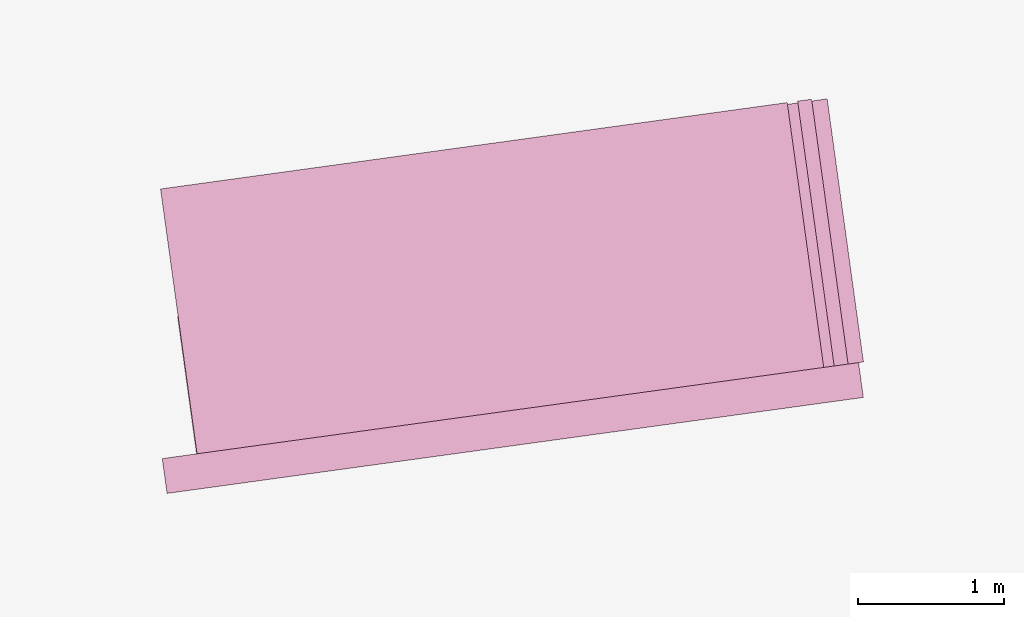
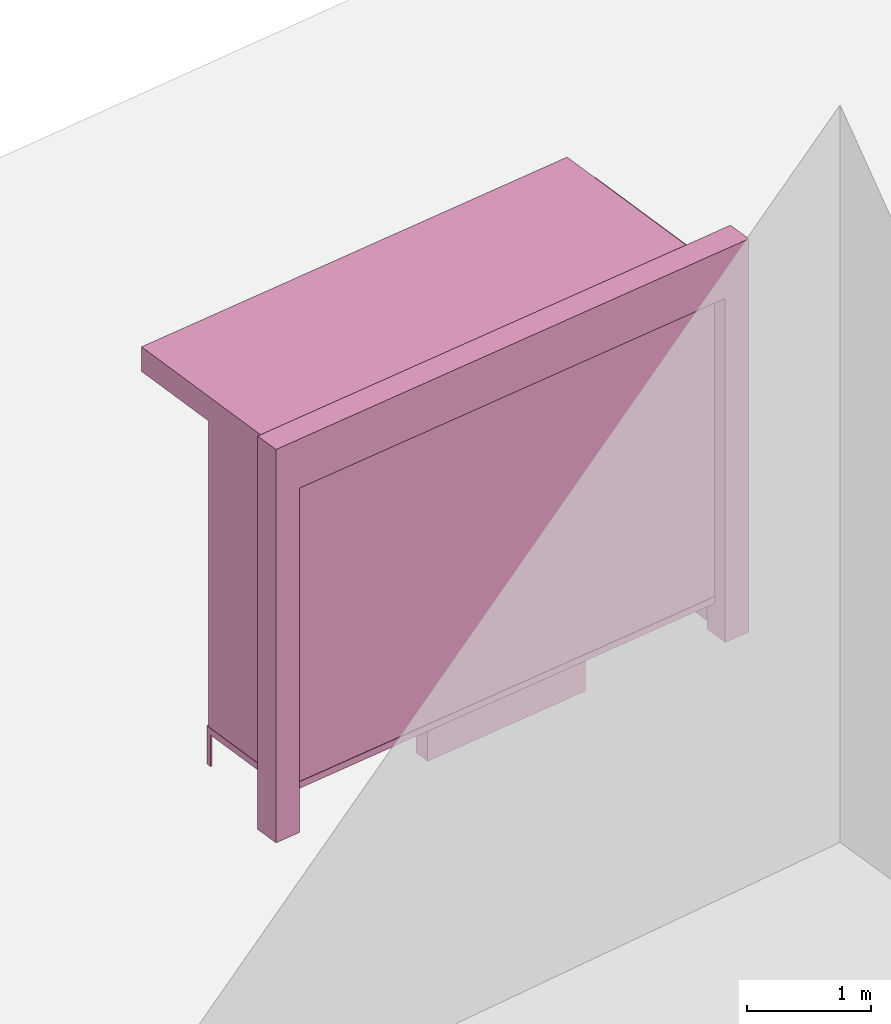
# One storey, part 3 of 200: 1 furnishing.
"""IFC4 building model written with IfcOpenShell, lengths in metres."""

from ifc_helpers import new_model, si_unit, origin_with_axes, place, context, subcontext, project, spatial, triangles, material, element, save


model = new_model("IFC4")

# Units and contexts
model_context = context("Model", 3, precision=1e-05, world=origin_with_axes())
body_context = subcontext(model_context, "Body", "Model", "MODEL_VIEW")
ifc_project = project(units=[si_unit("VOLUMEUNIT", "CUBIC_METRE"), si_unit("LENGTHUNIT", "METRE"), si_unit("AREAUNIT", "SQUARE_METRE")], contexts=[model_context])

# Site, building, storey
site_placement = place(None, origin_with_axes())
site = spatial("IfcSite", under=ifc_project, at=site_placement)
building_placement = place(site_placement, origin_with_axes())
building = spatial("IfcBuilding", under=site, at=building_placement, Name="Building")
storey_placement = place(building_placement, origin_with_axes())
storey = spatial("IfcBuildingStorey", under=building, at=storey_placement, Name="Ground")

# Furnishing
ifc_material = material(Name="busStop")
furnishing_placement = place(storey_placement, origin_with_axes())
element("IfcFurnishingElement", 1, at=furnishing_placement, inside=storey, material=ifc_material, Name="cw_instances_busStop_35", context=body_context, shape_type="Tessellation", body=[
    triangles([(311.0494212273711, -881.0792810811827, 3.3826375611235573), (307.034626620686, -883.7268433027492, 3.3826375611235573), (311.3327118678845, -883.1343512000307, 3.3826375611235573), (306.751335776538, -881.6717730010951, 3.3826375611235573), (311.0494212142046, -881.0792809856697, 3.6236783199298275), (307.0346266075195, -883.7268432072362, 3.6236783199298275), (306.7513357633715, -881.671772905582, 3.6236783199298275), (311.332711854718, -883.1343511045177, 3.6236783199298275), (311.0494212273711, -881.0792810811827, 3.3826375611235573), (306.7513357633715, -881.671772905582, 3.6236783199298275), (306.751335776538, -881.6717730010951, 3.3826375611235573), (311.0494212142046, -881.0792809856697, 3.6236783199298275), (306.751335776538, -881.6717730010951, 3.3826375611235573), (307.0346266075195, -883.7268432072362, 3.6236783199298275), (307.034626620686, -883.7268433027492, 3.3826375611235573), (306.7513357633715, -881.671772905582, 3.6236783199298275), (307.034626620686, -883.7268433027492, 3.3826375611235573), (311.332711854718, -883.1343511045177, 3.6236783199298275), (311.3327118678845, -883.1343512000307, 3.3826375611235573), (307.0346266075195, -883.7268432072362, 3.6236783199298275), (311.3327118678845, -883.1343512000307, 3.3826375611235573), (311.0494212142046, -881.0792809856697, 3.6236783199298275), (311.0494212273711, -881.0792810811827, 3.3826375611235573), (311.332711854718, -883.1343511045177, 3.6236783199298275), (311.29979552767463, -882.895568257491, 3.864718677001767), (311.5714944761658, -883.1014344354797, 3.864718677001767), (311.33271180424634, -883.1343507383845, 3.864718677001767), (311.53857819959404, -882.8626519545862, 3.864718677001767), (311.29979552767463, -882.895568257491, 3.6236783199298275), (311.53857819959404, -882.8626519545862, 3.864718677001767), (311.29979552767463, -882.895568257491, 3.864718677001767), (311.53857819959404, -882.8626519545862, 3.6236783199298275), (306.7629277869741, -883.5209764276422, 3.6236783199298275), (306.79584408987887, -883.7597590995615, 3.864718677001767), (306.79584408987887, -883.7597590995615, 3.6236783199298275), (306.7629277869741, -883.5209764276422, 3.864718677001767), (307.03462655485345, -883.7268428251842, 3.6236783199298275), (306.79584408987887, -883.7597590995615, 3.864718677001767), (307.03462655485345, -883.7268428251842, 3.864718677001767), (306.79584408987887, -883.7597590995615, 3.6236783199298275), (311.5714945003044, -883.1014346105869, 3.6236783199298275), (311.53857819959404, -882.8626519545862, 3.864718677001767), (311.53857819959404, -882.8626519545862, 3.6236783199298275), (311.5714944761658, -883.1014344354797, 3.864718677001767), (307.0017102782817, -883.4880603442908, 3.864718677001767), (307.03462655485345, -883.7268428251842, 3.864718677001767), (307.0017102782817, -883.4880603442908, 3.6236783199298275), (307.0017102782817, -883.4880603442908, 3.864718677001767), (311.5714945003044, -883.1014346105869, 3.6236783199298275), (311.33271180424634, -883.1343507383845, 3.864718677001767), (311.5714944761658, -883.1014344354797, 3.864718677001767), (311.33271180424634, -883.1343507383845, 3.6236783199298275), (306.7629277869741, -883.5209764276422, 3.864718677001767), (306.79584408987887, -883.7597590995615, 3.864718677001767), (306.7629277869741, -883.5209764276422, 3.6236783199298275), (306.7629277869741, -883.5209764276422, 3.864718677001767), (311.571494618803, -883.1014354702039, 9.480930192426488e-07), (311.53857835539776, -882.8626530848235, 8.998848996201414e-07), (311.3327119468836, -883.1343517731087, 9.480930192426488e-07), (311.571494618803, -883.1014354702039, 9.480930192426488e-07), (311.33271180424634, -883.1343507383845, 3.6236783199298275), (311.29979565933974, -882.8955692126211, 8.998848996201414e-07), (311.29979552767463, -882.895568257491, 3.6236783199298275), (311.3327119468836, -883.1343517731087, 9.480930192426488e-07), (311.53857835539776, -882.8626530848235, 8.998848996201414e-07), (311.29979565933974, -882.8955692126211, 8.998848996201414e-07), (306.76292945726146, -883.5209773653283, 8.998848996201414e-07), (306.79584423251606, -883.7597601342858, 9.480930192426488e-07), (307.0017119381549, -883.4880610887566, 8.998848996201414e-07), (306.76292945726146, -883.5209773653283, 8.998848996201414e-07), (307.0017102782817, -883.4880603442908, 3.6236783199298275), (307.0346282256988, -883.7268436492442, 9.480930192426488e-07), (307.03462655485345, -883.7268428251842, 3.6236783199298275), (307.0017119381549, -883.4880610887566, 8.998848996201414e-07), (306.79584423251606, -883.7597601342858, 9.480930192426488e-07), (307.0346282256988, -883.7268436492442, 9.480930192426488e-07), (306.87203481266494, -882.5455288646311, 0.3459945917589383), (307.01491268986865, -883.5819988890918, 3.3826375611235573), (307.0149128083672, -883.5819997487089, 0.34599476852204364), (306.87203470513845, -882.5455280846083, 3.3826375611235573), (307.03083162663046, -883.5798053321726, 0.34599476852204364), (306.8879535234017, -882.543333668072, 3.3826375611235573), (306.88795363092817, -882.5433344480949, 0.3459945917589383), (307.0308315081319, -883.5798044725556, 3.3826375611235573), (306.88795363092817, -882.5433344480949, 0.3459945917589383), (306.87203470513845, -882.5455280846083, 3.3826375611235573), (306.87203481266494, -882.5455288646311, 0.3459945917589383), (306.8879535234017, -882.543333668072, 3.3826375611235573), (307.034811430689, -883.5792567143234, 0.313856054245785), (306.8680552062157, -882.5460775039038, 0.3138558614133065), (307.01093319533476, -883.582548340225, 0.313856054245785), (306.89193344156996, -882.5427858780022, 0.3138558614133065), (307.034811430689, -883.5792567143234, 0.37813349886767544), (306.8680552040213, -882.546077487985, 0.37813330603519696), (306.8919334393755, -882.5427858620834, 0.37813330603519696), (307.01093319533476, -883.582548340225, 0.37813349886767544), (307.034811430689, -883.5792567143234, 0.313856054245785), (306.8919334393755, -882.5427858620834, 0.37813330603519696), (306.89193344156996, -882.5427858780022, 0.3138558614133065), (307.034811430689, -883.5792567143234, 0.37813349886767544), (306.8680552062157, -882.5460775039038, 0.3138558614133065), (307.01093319533476, -883.582548340225, 0.37813349886767544), (307.01093319533476, -883.582548340225, 0.313856054245785), (306.8680552040213, -882.546077487985, 0.37813330603519696), (306.8680552040213, -882.546077487985, 0.37813330603519696), (306.89193344156996, -882.5427858780022, 0.3138558614133065), (306.8919334393755, -882.5427858620834, 0.37813330603519696), (306.8680552062157, -882.5460775039038, 0.3138558614133065), (306.88521541321745, -882.5213750034779, 0.37813330603519696), (306.87477491593927, -882.567487984437, 0.37813330603519696), (306.8687314604219, -882.5236473240735, 0.37813330603519696), (306.89125886873484, -882.5652156638414, 0.37813330603519696), (306.88521544832815, -882.5213752581793, 1.446243588675227e-07), (306.8687314604219, -882.5236473240735, 0.37813330603519696), (306.8687314955326, -882.5236475787749, 1.446243588675227e-07), (306.88521541321745, -882.5213750034779, 0.37813330603519696), (306.8687314955326, -882.5236475787749, 1.446243588675227e-07), (306.87477491593927, -882.567487984437, 0.37813330603519696), (306.87477493130024, -882.5674880958688, 1.6069373207502523e-07), (306.8687314604219, -882.5236473240735, 0.37813330603519696), (306.87477493130024, -882.5674880958688, 1.6069373207502523e-07), (306.89125886873484, -882.5652156638414, 0.37813330603519696), (306.89125888409575, -882.5652157752731, 1.6069373207502523e-07), (306.87477491593927, -882.567487984437, 0.37813330603519696), (306.89125888409575, -882.5652157752731, 1.6069373207502523e-07), (306.88521541321745, -882.5213750034779, 0.37813330603519696), (306.88521544832815, -882.5213752581793, 1.446243588675227e-07), (306.89125886873484, -882.5652156638414, 0.37813330603519696), (309.9964752241491, -883.0087772994407, 1.1248564780513874), (308.4255449257231, -883.3802180753315, 1.1248565744676267), (308.40459174010925, -883.2282186949462, 1.1248564780513874), (310.01742838342994, -883.1607764887999, 1.1248565744676267), (308.4045917664423, -883.2282188859723, 4.981505694325782e-07), (309.9964752241491, -883.0087772994407, 0.964162810253855), (308.40459174010925, -883.2282186949462, 0.964162810253855), (309.9964752702319, -883.0087776337363, 4.981505694325782e-07), (308.42554497838915, -883.3802184573835, 5.302893158475833e-07), (308.40459174010925, -883.2282186949462, 0.964162810253855), (308.4255449257231, -883.3802180753315, 0.9641629066700942), (308.4045917664423, -883.2282188859723, 4.981505694325782e-07), (310.01742843609594, -883.1607768708519, 5.302893158475833e-07), (308.4255449257231, -883.3802180753315, 0.9641629066700942), (310.01742838342994, -883.1607764887999, 0.9641629066700942), (308.42554497838915, -883.3802184573835, 5.302893158475833e-07), (309.9964752702319, -883.0087776337363, 4.981505694325782e-07), (310.01742838342994, -883.1607764887999, 0.9641629066700942), (309.9964752241491, -883.0087772994407, 0.964162810253855), (310.01742843609594, -883.1607768708519, 5.302893158475833e-07), (308.3168149996587, -882.5914653913387, 1.124856381635148), (309.9086984727264, -882.372023916239, 0.9641627138376155), (309.9086984683376, -882.3720238844013, 1.124856381635148), (308.3168150018531, -882.5914654072576, 0.9641627138376155), (308.4255449257231, -883.3802180753315, 1.1248565744676267), (308.40459174010925, -883.2282186949462, 1.1248564780513874), (310.01742838342994, -883.1607764887999, 1.1248565744676267), (308.4255449257231, -883.3802180753315, 1.1248565744676267), (309.9964752241491, -883.0087772994407, 1.1248564780513874), (310.01742838342994, -883.1607764887999, 1.1248565744676267), (309.9086984683376, -882.3720238844013, 1.124856381635148), (308.3168149996587, -882.5914653913387, 1.124856381635148), (309.9086984727264, -882.372023916239, 0.9641627138376155), (309.9086984683376, -882.3720238844013, 1.124856381635148), (308.3168149996587, -882.5914653913387, 1.124856381635148), (308.3168150018531, -882.5914654072576, 0.9641627138376155), (311.4500176654389, -882.962508874376, 0.34599476852204364), (306.8941759271089, -883.5905317592359, 3.503157940526693), (306.8941760565796, -883.5905326984471, 0.34599476852204364), (311.4500175732733, -882.962508205785, 3.503157940526693), (306.89637047531033, -883.6064515326292, 0.34599476852204364), (311.4522119898096, -882.9784270240482, 3.503157940526693), (311.4522120819752, -882.9784276926392, 0.34599476852204364), (306.8963703436452, -883.6064505774991, 3.503157940526693), (311.5430195727416, -882.7647127486322, 0.5810001600002933), (311.3206504372498, -881.151594274217, 3.2193552137185355), (311.3206505162489, -881.1515948472951, 0.5809998707515756), (311.54301948935375, -882.7647121437165, 3.2193552137185355), (311.5721049033891, -882.8580313371883, 0.4845839046859049), (311.33656933451215, -881.1494004307588, 0.5809998707515756), (311.3234043475837, -881.0538873127095, 0.48458358329844076), (311.55893839100486, -882.7625183320959, 0.5810001600002933), (311.3365692555131, -881.1493998576807, 3.2193552137185355), (311.3234027167958, -881.0538866615623, 3.3157713565473115), (311.558938307617, -882.7625177271801, 3.2193552137185355), (311.5721048134179, -882.858030684516, 3.3157713565473115), (311.55893839100486, -882.7625183320959, 0.5810001600002933), (311.3206505162489, -881.1515948472951, 0.5809998707515756), (311.33656933451215, -881.1494004307588, 0.5809998707515756), (311.5430195727416, -882.7647127486322, 0.5810001600002933), (311.33656933451215, -881.1494004307588, 0.5809998707515756), (311.3206504372498, -881.151594274217, 3.2193552137185355), (311.3365692555131, -881.1493998576807, 3.2193552137185355), (311.3206505162489, -881.1515948472951, 0.5809998707515756), (311.3365692555131, -881.1493998576807, 3.2193552137185355), (311.54301948935375, -882.7647121437165, 3.2193552137185355), (311.558938307617, -882.7625177271801, 3.2193552137185355), (311.3206504372498, -881.151594274217, 3.2193552137185355), (311.558938307617, -882.7625177271801, 3.2193552137185355), (311.5430195727416, -882.7647127486322, 0.5810001600002933), (311.55893839100486, -882.7625183320959, 0.5810001600002933), (311.54301948935375, -882.7647121437165, 3.2193552137185355), (311.01756692256066, -881.0960462687115, 3.3157713565473115), (311.5721048134179, -882.858030684516, 3.3157713565473115), (311.2662689796833, -882.9001900051263, 3.3157713565473115), (311.3234027167958, -881.0538866615623, 3.3157713565473115), (311.0175670410593, -881.0960471283286, 0.48458358329844076), (311.3234027167958, -881.0538866615623, 3.3157713565473115), (311.01756692256066, -881.0960462687115, 3.3157713565473115), (311.3234043475837, -881.0538873127095, 0.48458358329844076), (311.5721049033891, -882.8580313371883, 0.4845839046859049), (311.2662689796833, -882.9001900051263, 3.3157713565473115), (311.5721048134179, -882.858030684516, 3.3157713565473115), (311.2662690850154, -882.9001907692303, 0.4845839046859049), (311.2690213952832, -882.8024833794393, 0.5810001600002933), (311.04665227954115, -881.1893650482937, 3.2193552137185355), (311.26902128556225, -882.8024825834975, 3.2193552137185355), (311.04665235854026, -881.1893656213717, 0.5809998707515756), (311.2662690850154, -882.9001907692303, 0.4845839046859049), (311.030733540277, -881.191560037908, 0.5809998707515756), (311.25310257701994, -882.8046777959755, 0.5810001600002933), (311.0175670410593, -881.0960471283286, 0.48458358329844076), (311.0307334612779, -881.19155946483, 3.2193552137185355), (311.01756692256066, -881.0960462687115, 3.3157713565473115), (311.253102467299, -882.8046770000338, 3.2193552137185355), (311.2662689796833, -882.9001900051263, 3.3157713565473115), (311.25310257701994, -882.8046777959755, 0.5810001600002933), (311.04665235854026, -881.1893656213717, 0.5809998707515756), (311.2690213952832, -882.8024833794393, 0.5810001600002933), (311.030733540277, -881.191560037908, 0.5809998707515756), (311.030733540277, -881.191560037908, 0.5809998707515756), (311.04665227954115, -881.1893650482937, 3.2193552137185355), (311.04665235854026, -881.1893656213717, 0.5809998707515756), (311.0307334612779, -881.19155946483, 3.2193552137185355), (311.0307334612779, -881.19155946483, 3.2193552137185355), (311.26902128556225, -882.8024825834975, 3.2193552137185355), (311.04665227954115, -881.1893650482937, 3.2193552137185355), (311.253102467299, -882.8046770000338, 3.2193552137185355), (311.253102467299, -882.8046770000338, 3.2193552137185355), (311.2690213952832, -882.8024833794393, 0.5810001600002933), (311.26902128556225, -882.8024825834975, 3.2193552137185355), (311.25310257701994, -882.8046777959755, 0.5810001600002933), (311.2165673148053, -881.0562399149243, 3.3287619342644956), (311.37143046151067, -882.8856937376995, 3.3287619342644956), (311.1210559175151, -881.0694062056722, 3.3287619342644956), (311.4669433710901, -882.8725272384818, 3.3287619342644956), (311.2165691102861, -881.0562403487124, 0.0), (311.1210559175151, -881.0694062056722, 3.3287619342644956), (311.1210560096807, -881.0694068742632, 0.0), (311.2165673148053, -881.0562399149243, 3.3287619342644956), (311.1210560096807, -881.0694068742632, 0.0), (311.37143046151067, -882.8856937376995, 3.3287619342644956), (311.37143056464834, -882.8856944858848, 5.142199426400808e-07), (311.1210559175151, -881.0694062056722, 3.3287619342644956), (311.37143056464834, -882.8856944858848, 5.142199426400808e-07), (311.4669433710901, -882.8725272384818, 3.3287619342644956), (311.4669434742278, -882.872527986667, 5.142199426400808e-07), (311.37143046151067, -882.8856937376995, 3.3287619342644956), (311.4669434742278, -882.872527986667, 5.142199426400808e-07), (311.2165673148053, -881.0562399149243, 3.3287619342644956), (311.2165691102861, -881.0562403487124, 0.0), (311.4669433710901, -882.8725272384818, 3.3287619342644956), (311.4494690607562, -882.9585291658306, 0.313856054245785), (306.99548687258056, -883.5968437060135, 0.313856054245785), (311.45276069982435, -882.9824074966978, 0.313856054245785), (306.9921952488733, -883.572965486578, 0.313856054245785), (311.4494690607562, -882.9585291658306, 0.37813349886767544), (306.99548687258056, -883.5968437060135, 0.37813349886767544), (306.9921952488733, -883.572965486578, 0.37813349886767544), (311.45276069982435, -882.9824074966978, 0.37813349886767544), (311.4494690607562, -882.9585291658306, 0.313856054245785), (306.9921952488733, -883.572965486578, 0.37813349886767544), (306.9921952488733, -883.572965486578, 0.313856054245785), (311.4494690607562, -882.9585291658306, 0.37813349886767544), (306.99548687258056, -883.5968437060135, 0.313856054245785), (311.45276069982435, -882.9824074966978, 0.37813349886767544), (311.45276069982435, -882.9824074966978, 0.313856054245785), (306.99548687258056, -883.5968437060135, 0.37813349886767544), (309.85811526777843, -883.1818190673338, 1.5290613779533648), (308.5846084251282, -883.3573718993937, 2.8146110577904615), (309.8581152151124, -883.1818186852818, 2.8146110577904615), (308.58460847779423, -883.3573722814457, 1.5290613779533648), (309.8244330363039, -883.1728271239731, 1.5612002850621018), (308.61460156441404, -883.3396022926402, 2.7824723435142027), (308.6146016412187, -883.3396028497993, 1.5612002850621018), (309.8244330099709, -883.172826932947, 2.7824723435142027), (309.85811526777843, -883.1818190673338, 1.5290613779533648), (308.5805695140664, -883.3280726801659, 1.5290613779533648), (308.58460847779423, -883.3573722814457, 1.5290613779533648), (309.85407633038363, -883.15251965708, 1.5290613779533648), (308.58460847779423, -883.3573722814457, 1.5290613779533648), (308.5805694899278, -883.3280725050587, 2.8146110577904615), (308.5846084251282, -883.3573718993937, 2.8146110577904615), (308.5805695140664, -883.3280726801659, 1.5290613779533648), (308.5846084251282, -883.3573718993937, 2.8146110577904615), (309.8540762777176, -883.152519275028, 2.8146110577904615), (309.8581152151124, -883.1818186852818, 2.8146110577904615), (308.5805694899278, -883.3280725050587, 2.8146110577904615), (309.8581152151124, -883.1818186852818, 2.8146110577904615), (309.85407633038363, -883.15251965708, 1.5290613779533648), (309.85811526777843, -883.1818190673338, 1.5290613779533648), (309.8540762777176, -883.152519275028, 2.8146110577904615), (308.2128361878671, -883.4086212653376, 1.5290613779533648), (307.41689427791835, -883.5183414509354, 2.8146110577904615), (308.212836013355, -883.4086207054261, 2.8146110577904615), (307.4168943305844, -883.5183418329874, 1.5290613779533648), (308.1791538394561, -883.3996295327526, 1.5612002850621018), (307.44688740894725, -883.5005721373041, 2.7824723435142027), (307.4468874484468, -883.5005724238431, 1.5612002850621018), (308.1791537626514, -883.3996289755934, 2.7824723435142027), (308.2128361878671, -883.4086212653376, 1.5290613779533648), (307.412855395384, -883.4890424386524, 1.5290613779533648), (307.4168943305844, -883.5183418329874, 1.5290613779533648), (308.20879722413923, -883.3793216640578, 1.5290613779533648), (307.4168943305844, -883.5183418329874, 1.5290613779533648), (307.41285534271793, -883.4890420566004, 2.8146110577904615), (307.41689427791835, -883.5183414509354, 2.8146110577904615), (307.412855395384, -883.4890424386524, 1.5290613779533648), (307.41689427791835, -883.5183414509354, 2.8146110577904615), (308.2087970781546, -883.3793213110911, 2.8146110577904615), (308.212836013355, -883.4086207054261, 2.8146110577904615), (307.41285534271793, -883.4890420566004, 2.8146110577904615), (308.212836013355, -883.4086207054261, 2.8146110577904615), (308.20879722413923, -883.3793216640578, 1.5290613779533648), (308.2128361878671, -883.4086212653376, 1.5290613779533648), (308.2087970781546, -883.3793213110911, 2.8146110577904615), (309.85407633038363, -883.15251965708, 1.5290613779533648), (308.6124072115159, -883.323683936023, 1.5612002850621018), (308.5805695140664, -883.3280726801659, 1.5290613779533648), (309.82223864610063, -883.1569084967358, 1.5612002850621018), (308.6124071742108, -883.3236836654029, 2.7824723435142027), (308.5805694899278, -883.3280725050587, 2.8146110577904615), (309.8222385934346, -883.1569081146838, 2.7824723435142027), (309.8540762777176, -883.152519275028, 2.8146110577904615), (308.20879722413923, -883.3793216640578, 1.5290613779533648), (307.4446930319105, -883.4846536055799, 1.5612002850621018), (307.412855395384, -883.4890424386524, 1.5290613779533648), (308.17695939658677, -883.3837105234634, 1.5612002850621018), (307.44469297924445, -883.4846532235277, 2.7824723435142027), (307.41285534271793, -883.4890420566004, 2.8146110577904615), (308.17695934611515, -883.3837101573301, 2.7824723435142027), (308.2087970781546, -883.3793213110911, 2.8146110577904615), (309.82223864610063, -883.1569084967358, 1.5612002850621018), (308.6146016412187, -883.3396028497993, 1.5612002850621018), (308.6124072115159, -883.323683936023, 1.5612002850621018), (309.8244330363039, -883.1728271239731, 1.5612002850621018), (308.6124072115159, -883.323683936023, 1.5612002850621018), (308.61460156441404, -883.3396022926402, 2.7824723435142027), (308.6124071742108, -883.3236836654029, 2.7824723435142027), (308.6146016412187, -883.3396028497993, 1.5612002850621018), (308.6124071742108, -883.3236836654029, 2.7824723435142027), (309.8244330099709, -883.172826932947, 2.7824723435142027), (309.8222385934346, -883.1569081146838, 2.7824723435142027), (308.61460156441404, -883.3396022926402, 2.7824723435142027), (309.8222385934346, -883.1569081146838, 2.7824723435142027), (309.8244330363039, -883.1728271239731, 1.5612002850621018), (309.82223864610063, -883.1569084967358, 1.5612002850621018), (309.8244330099709, -883.172826932947, 2.7824723435142027), (308.17695939658677, -883.3837105234634, 1.5612002850621018), (307.4468874484468, -883.5005724238431, 1.5612002850621018), (307.4446930319105, -883.4846536055799, 1.5612002850621018), (308.1791538394561, -883.3996295327526, 1.5612002850621018), (307.4446930319105, -883.4846536055799, 1.5612002850621018), (307.44688740894725, -883.5005721373041, 2.7824723435142027), (307.44469297924445, -883.4846532235277, 2.7824723435142027), (307.4468874484468, -883.5005724238431, 1.5612002850621018), (307.44469297924445, -883.4846532235277, 2.7824723435142027), (308.1791537626514, -883.3996289755934, 2.7824723435142027), (308.17695934611515, -883.3837101573301, 2.7824723435142027), (307.44688740894725, -883.5005721373041, 2.7824723435142027), (308.17695934611515, -883.3837101573301, 2.7824723435142027), (308.1791538394561, -883.3996295327526, 1.5612002850621018), (308.17695939658677, -883.3837105234634, 1.5612002850621018), (308.1791537626514, -883.3996289755934, 2.7824723435142027)], [[1, 3, 2], [2, 4, 1], [5, 7, 6], [6, 8, 5], [9, 11, 10], [10, 12, 9], [13, 15, 14], [14, 16, 13], [17, 19, 18], [18, 20, 17], [21, 23, 22], [22, 24, 21], [25, 27, 26], [26, 28, 25], [29, 31, 30], [30, 32, 29], [33, 35, 34], [34, 36, 33], [37, 39, 38], [38, 40, 37], [41, 43, 42], [42, 44, 41], [45, 46, 27], [27, 25, 45], [47, 48, 31], [31, 29, 47], [49, 51, 50], [50, 52, 49], [52, 50, 39], [39, 37, 52], [53, 54, 46], [46, 45, 53], [55, 56, 48], [48, 47, 55], [43, 41, 57], [57, 58, 43], [49, 52, 59], [59, 60, 49], [61, 63, 62], [62, 64, 61], [29, 32, 65], [65, 66, 29], [35, 33, 67], [67, 68, 35], [55, 47, 69], [69, 70, 55], [71, 73, 72], [72, 74, 71], [37, 40, 75], [75, 76, 37], [77, 79, 78], [78, 80, 77], [81, 83, 82], [82, 84, 81], [85, 87, 86], [86, 88, 85], [89, 91, 90], [90, 92, 89], [93, 95, 94], [94, 96, 93], [97, 99, 98], [98, 100, 97], [101, 103, 102], [102, 104, 101], [105, 107, 106], [106, 108, 105], [109, 111, 110], [110, 112, 109], [113, 115, 114], [114, 116, 113], [117, 119, 118], [118, 120, 117], [121, 123, 122], [122, 124, 121], [125, 127, 126], [126, 128, 125], [129, 131, 130], [130, 132, 129], [133, 135, 134], [134, 136, 133], [137, 139, 138], [138, 140, 137], [141, 143, 142], [142, 144, 141], [145, 147, 146], [146, 148, 145], [149, 151, 150], [150, 152, 149], [153, 154, 138], [138, 139, 153], [155, 156, 142], [142, 143, 155], [157, 158, 146], [146, 147, 157], [131, 129, 159], [159, 160, 131], [157, 147, 161], [161, 162, 157], [138, 154, 163], [163, 164, 138], [165, 167, 166], [166, 168, 165], [169, 171, 170], [170, 172, 169], [173, 175, 174], [174, 176, 173], [177, 179, 178], [178, 180, 177], [179, 182, 181], [181, 178, 179], [182, 184, 183], [183, 181, 182], [184, 177, 180], [180, 183, 184], [185, 187, 186], [186, 188, 185], [189, 191, 190], [190, 192, 189], [193, 195, 194], [194, 196, 193], [197, 199, 198], [198, 200, 197], [201, 203, 202], [202, 204, 201], [205, 207, 206], [206, 208, 205], [209, 211, 210], [210, 212, 209], [213, 215, 214], [214, 216, 213], [217, 219, 218], [218, 220, 217], [220, 218, 221], [221, 222, 220], [222, 221, 223], [223, 224, 222], [224, 223, 219], [219, 217, 224], [225, 227, 226], [226, 228, 225], [229, 231, 230], [230, 232, 229], [233, 235, 234], [234, 236, 233], [237, 239, 238], [238, 240, 237], [241, 243, 242], [242, 244, 241], [245, 247, 246], [246, 248, 245], [249, 251, 250], [250, 252, 249], [253, 255, 254], [254, 256, 253], [257, 259, 258], [258, 260, 257], [261, 263, 262], [262, 264, 261], [265, 267, 266], [266, 268, 265], [269, 271, 270], [270, 272, 269], [273, 275, 274], [274, 276, 273], [277, 279, 278], [278, 280, 277], [281, 283, 282], [282, 284, 281], [285, 287, 286], [286, 288, 285], [289, 291, 290], [290, 292, 289], [293, 295, 294], [294, 296, 293], [297, 299, 298], [298, 300, 297], [301, 303, 302], [302, 304, 301], [305, 307, 306], [306, 308, 305], [309, 311, 310], [310, 312, 309], [313, 315, 314], [314, 316, 313], [317, 319, 318], [318, 320, 317], [321, 323, 322], [322, 324, 321], [325, 327, 326], [326, 328, 325], [327, 330, 329], [329, 326, 327], [330, 332, 331], [331, 329, 330], [332, 325, 328], [328, 331, 332], [333, 335, 334], [334, 336, 333], [335, 338, 337], [337, 334, 335], [338, 340, 339], [339, 337, 338], [340, 333, 336], [336, 339, 340], [341, 343, 342], [342, 344, 341], [345, 347, 346], [346, 348, 345], [349, 351, 350], [350, 352, 349], [353, 355, 354], [354, 356, 353], [357, 359, 358], [358, 360, 357], [361, 363, 362], [362, 364, 361], [365, 367, 366], [366, 368, 365], [369, 371, 370], [370, 372, 369]], closed=True),
])

save(model, "model.ifc")
